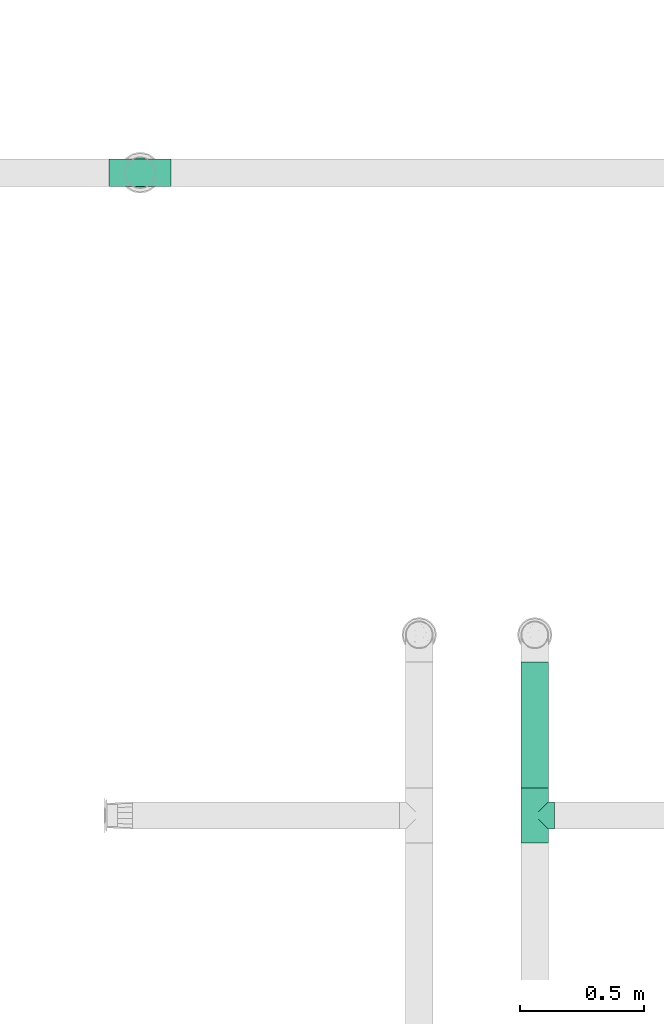
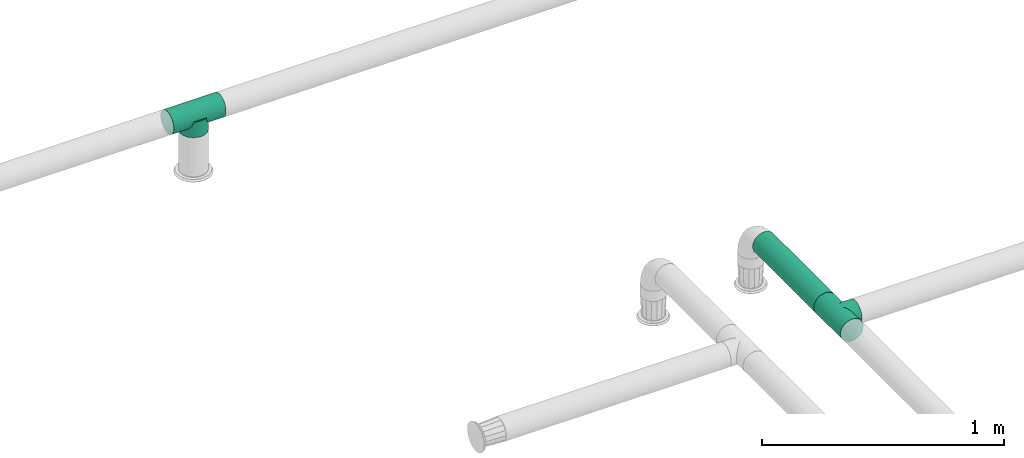
# One storey, part 75 of 115: 2 flow fittings, 1 flow segment.
"""IFC2X3 building model written with IfcOpenShell, lengths in millimetres."""

from ifc_helpers import new_model, entity, si_unit, converted_unit, derived_unit, direction, frame, origin_with_axes, origin_2d_with_axis, place, context, subcontext, project, spatial, hollow_circle, extrude, open_shell, surface_model, source, transform, mapped, material, layer, layer_set, layer_usage, type_object, element, save


model = new_model("IFC2X3")

# Units and contexts
model_context = context("Model", 3, precision=1e-05, world=origin_with_axes(), true_north=direction((0.0, 1.0)))
body_context = subcontext(model_context, "Body", "Model", "MODEL_VIEW")
ifc_project = project(units=[si_unit("AREAUNIT", "SQUARE_METRE"), si_unit("VOLUMEUNIT", "CUBIC_METRE", prefix="DECI"), si_unit("TIMEUNIT", "SECOND"), si_unit("THERMODYNAMICTEMPERATUREUNIT", "DEGREE_CELSIUS"), si_unit("PRESSUREUNIT", "PASCAL"), si_unit("MASSUNIT", "GRAM", prefix="KILO"), si_unit("LENGTHUNIT", "METRE", prefix="MILLI"), si_unit("POWERUNIT", "WATT"), si_unit("ELECTRICCURRENTUNIT", "AMPERE"), si_unit("ELECTRICVOLTAGEUNIT", "VOLT"), derived_unit("VOLUMETRICFLOWRATEUNIT", [(si_unit("VOLUMEUNIT", "CUBIC_METRE", prefix="DECI"), 1), (si_unit("TIMEUNIT", "SECOND"), -1)]), derived_unit("LINEARVELOCITYUNIT", [(si_unit("LENGTHUNIT", "METRE"), 1), (si_unit("TIMEUNIT", "SECOND"), -1)]), derived_unit("MASSDENSITYUNIT", [(si_unit("MASSUNIT", "GRAM", prefix="KILO"), 1), (si_unit("VOLUMEUNIT", "CUBIC_METRE"), -1)]), converted_unit("PLANEANGLEUNIT", "DEGREE", entity("IfcRatioMeasure", 0.01745), si_unit("PLANEANGLEUNIT", "RADIAN"), dimensions=[0, 0, 0, 0, 0, 0, 0])], contexts=[model_context])

# Site, building, storey
site_placement = place(None, origin_with_axes())
site = spatial("IfcSite", under=ifc_project, at=site_placement, CompositionType="ELEMENT")
building_placement = place(site_placement, origin_with_axes())
building = spatial("IfcBuilding", under=site, at=building_placement, Name="mc-building", CompositionType="ELEMENT")
storey_placement = place(building_placement, frame((0.0, 0.0, 2950.0), z_axis=(0.0, 0.0, 1.0), x_axis=(1.0, 0.0, 0.0)))
storey = spatial("IfcBuildingStorey", under=building, at=storey_placement, Name="2. Korrus", CompositionType="ELEMENT", Elevation=2950.0)

# Flow fittings
duct_fitting_type = type_object("IfcDuctFittingType", PredefinedType="JUNCTION")
shared_shape_1 = source(origin_with_axes(), body_context, "Body", "SurfaceModel", [
    surface_model("IfcShellBasedSurfaceModel", [(0.0, -80.0, -55.0), (14.23505, -80.0, -53.12592), (-14.23505, -80.0, -53.12592), (-53.12592, -80.0, 14.23505), (-27.5, -80.0, -47.63139), (-47.63139, -80.0, -27.5), (-38.89087, -80.0, -38.89087), (55.0, -80.0, 0.0), (53.12592, -80.0, 14.23505), (38.89087, -80.0, -38.89087), (27.5, -80.0, -47.63139), (53.12592, -80.0, -14.23505), (47.63139, -80.0, -27.5), (-53.12592, -80.0, -14.23505), (-47.63139, -80.0, 27.5), (-38.89087, -80.0, 38.89087), (14.23505, -80.0, 53.12592), (-27.5, -80.0, 47.63139), (-14.23505, -80.0, 53.12592), (47.63139, -80.0, 27.5), (38.89087, -80.0, 38.89087), (27.5, -80.0, 47.63139), (0.0, -80.0, 55.0), (-55.0, -80.0, 0.0), (0.0, 0.0, 55.0), (-7.4066, -7.4066, 54.49901), (-14.74521, -14.74521, 52.98659), (-21.93978, -21.93978, 50.43457), (-28.89905, -28.89905, 46.79578), (-35.50357, -35.50357, 42.00591), (-41.58668, -41.58668, 35.99373), (-46.92319, -46.92319, 28.69171), (-51.19777, -51.19777, 20.0945), (-50.37866, -80.0, 20.86752), (-54.01174, -54.01174, 10.37938), (-55.0, -55.0, 0.0), (-54.06296, -80.0, 7.11752), (-54.01174, -54.01174, -10.37938), (-51.19777, -51.19777, -20.0945), (-54.06296, -80.0, -7.11752), (-46.92319, -46.92319, -28.69171), (-41.58668, -41.58668, -35.99373), (-50.37866, -80.0, -20.86752), (-35.50357, -35.50357, -42.00591), (-21.93978, -21.93978, -50.43457), (-14.74521, -14.74521, -52.98659), (-7.4066, -7.4066, -54.49901), (0.0, 0.0, -55.0), (-28.89905, -28.89905, -46.79578), (7.4066, -7.4066, -54.49901), (14.74521, -14.74521, -52.98659), (21.93978, -21.93978, -50.43457), (28.89905, -28.89905, -46.79578), (35.50357, -35.50357, -42.00591), (41.58668, -41.58668, -35.99373), (46.92319, -46.92319, -28.69171), (51.19777, -51.19777, -20.0945), (50.37866, -80.0, -20.86752), (54.01174, -54.01174, -10.37938), (55.0, -55.0, 0.0), (54.06296, -80.0, -7.11752), (54.01174, -54.01174, 10.37938), (51.19777, -51.19777, 20.0945), (54.06296, -80.0, 7.11752), (46.92319, -46.92319, 28.69171), (41.58668, -41.58668, 35.99373), (50.37866, -80.0, 20.86752), (35.50357, -35.50357, 42.00591), (21.93978, -21.93978, 50.43457), (14.74521, -14.74521, 52.98659), (7.4066, -7.4066, 54.49901), (28.89905, -28.89905, 46.79578), (-110.0, 0.0, -55.0), (-110.0, -14.23505, -53.12592), (-110.0, 14.23505, -53.12592), (-110.0, 53.12592, 14.23505), (-110.0, 27.5, -47.63139), (-110.0, 47.63139, -27.5), (-110.0, 38.89087, -38.89087), (-110.0, -55.0, 0.0), (-110.0, -53.12592, 14.23505), (-110.0, -38.89087, -38.89087), (-110.0, -27.5, -47.63139), (-110.0, -53.12592, -14.23505), (-110.0, -47.63139, -27.5), (-110.0, 53.12592, -14.23505), (-110.0, 47.63139, 27.5), (-110.0, 38.89087, 38.89087), (-110.0, -14.23505, 53.12592), (-110.0, 27.5, 47.63139), (-110.0, 14.23505, 53.12592), (-110.0, -47.63139, 27.5), (-110.0, -38.89087, 38.89087), (-110.0, -27.5, 47.63139), (-110.0, 0.0, 55.0), (-110.0, 55.0, 0.0), (110.0, 55.0, 0.0), (110.0, 0.0, -55.0), (110.0, 14.23505, -53.12592), (110.0, 27.5, -47.63139), (110.0, 38.89087, -38.89087), (110.0, 47.63139, -27.5), (110.0, -38.89087, -38.89087), (110.0, -53.12592, 14.23505), (110.0, -27.5, -47.63139), (110.0, -14.23505, -53.12592), (110.0, -47.63139, -27.5), (110.0, -53.12592, -14.23505), (110.0, -55.0, 0.0), (110.0, 53.12592, -14.23505), (110.0, 53.12592, 14.23505), (110.0, 47.63139, 27.5), (110.0, 38.89087, 38.89087), (110.0, 0.0, 55.0), (110.0, 27.5, 47.63139), (110.0, 14.23505, 53.12592), (110.0, -47.63139, 27.5), (110.0, -38.89087, 38.89087), (110.0, -27.5, 47.63139), (110.0, -14.23505, 53.12592)], [open_shell([[[0, 1, 2]], [[2, 3, 4]], [[5, 6, 3]], [[6, 4, 3]], [[2, 7, 8]], [[9, 7, 10]], [[1, 10, 7]], [[11, 7, 12]], [[9, 12, 7]], [[7, 2, 1]], [[5, 3, 13]], [[2, 14, 3]], [[2, 15, 14]], [[2, 16, 17]], [[17, 15, 2]], [[16, 18, 17]], [[2, 8, 19]], [[2, 19, 20]], [[2, 20, 21]], [[16, 2, 21]], [[16, 22, 18]], [[23, 13, 3]], [[24, 25, 22]], [[26, 27, 18]], [[25, 26, 18]], [[22, 25, 18]], [[17, 28, 29]], [[17, 18, 27]], [[17, 29, 15]], [[28, 17, 27]], [[30, 31, 14]], [[32, 3, 33]], [[32, 34, 3]], [[35, 36, 34]], [[31, 32, 14]], [[15, 30, 14]], [[34, 36, 3]], [[33, 14, 32]], [[36, 35, 23]], [[30, 15, 29]], [[37, 38, 13]], [[37, 13, 39]], [[40, 41, 5]], [[38, 5, 42]], [[38, 40, 5]], [[37, 39, 35]], [[35, 39, 23]], [[13, 38, 42]], [[41, 6, 5]], [[41, 43, 6]], [[44, 45, 2]], [[46, 47, 0]], [[45, 46, 2]], [[43, 48, 4]], [[44, 4, 48]], [[44, 2, 4]], [[46, 0, 2]], [[43, 4, 6]], [[47, 49, 0]], [[50, 51, 1]], [[49, 50, 1]], [[0, 49, 1]], [[10, 52, 53]], [[10, 1, 51]], [[10, 53, 9]], [[52, 10, 51]], [[54, 55, 12]], [[56, 11, 57]], [[56, 58, 11]], [[59, 60, 58]], [[55, 56, 12]], [[9, 54, 12]], [[58, 60, 11]], [[57, 12, 56]], [[60, 59, 7]], [[54, 9, 53]], [[61, 62, 8]], [[61, 8, 63]], [[64, 65, 19]], [[62, 19, 66]], [[62, 64, 19]], [[61, 63, 59]], [[7, 59, 63]], [[62, 66, 8]], [[65, 20, 19]], [[65, 67, 20]], [[68, 69, 16]], [[70, 24, 22]], [[69, 70, 16]], [[67, 71, 21]], [[68, 21, 71]], [[68, 16, 21]], [[70, 22, 16]], [[67, 21, 20]], [[72, 73, 74]], [[74, 75, 76]], [[77, 78, 75]], [[76, 75, 78]], [[74, 79, 80]], [[81, 79, 82]], [[73, 82, 79]], [[83, 79, 84]], [[81, 84, 79]], [[79, 74, 73]], [[77, 75, 85]], [[74, 86, 75]], [[74, 87, 86]], [[74, 88, 89]], [[89, 87, 74]], [[88, 90, 89]], [[74, 91, 92]], [[91, 74, 80]], [[92, 93, 74]], [[74, 93, 88]], [[88, 94, 90]], [[95, 85, 75]], [[96, 97, 98]], [[99, 96, 98]], [[96, 100, 101]], [[100, 96, 99]], [[102, 97, 103]], [[97, 102, 104]], [[104, 105, 97]], [[102, 103, 106]], [[106, 103, 107]], [[108, 107, 103]], [[109, 96, 101]], [[110, 111, 97]], [[97, 111, 112]], [[113, 97, 114]], [[97, 112, 114]], [[113, 114, 115]], [[116, 103, 97]], [[117, 116, 97]], [[118, 117, 97]], [[119, 118, 97]], [[119, 97, 113]], [[96, 110, 97]], [[24, 113, 115]], [[89, 115, 114]], [[94, 24, 90]], [[90, 24, 115]], [[115, 89, 90]], [[114, 87, 89]], [[86, 112, 111]], [[75, 111, 110]], [[95, 110, 96]], [[87, 112, 86]], [[86, 111, 75]], [[110, 95, 75]], [[112, 87, 114]], [[85, 96, 109]], [[77, 109, 101]], [[95, 96, 85]], [[85, 109, 77]], [[101, 78, 77]], [[101, 100, 78]], [[76, 100, 99]], [[74, 99, 98]], [[47, 98, 97]], [[76, 99, 74]], [[47, 72, 74]], [[98, 47, 74]], [[100, 76, 78]], [[47, 46, 72]], [[45, 44, 73]], [[46, 45, 73]], [[72, 46, 73]], [[82, 48, 43]], [[82, 73, 44]], [[82, 43, 81]], [[48, 82, 44]], [[41, 40, 84]], [[38, 37, 83]], [[40, 38, 84]], [[81, 41, 84]], [[37, 79, 83]], [[83, 84, 38]], [[79, 37, 35]], [[41, 81, 43]], [[49, 97, 105]], [[105, 104, 51]], [[53, 104, 102]], [[53, 52, 104]], [[49, 47, 97]], [[51, 50, 105]], [[52, 51, 104]], [[49, 105, 50]], [[54, 102, 106]], [[56, 106, 107]], [[58, 107, 108]], [[55, 54, 106]], [[58, 56, 107]], [[59, 58, 108]], [[55, 106, 56]], [[102, 54, 53]], [[34, 32, 80]], [[31, 30, 91]], [[32, 31, 91]], [[35, 34, 79]], [[80, 79, 34]], [[32, 91, 80]], [[30, 92, 91]], [[30, 29, 92]], [[27, 26, 88]], [[25, 24, 94]], [[26, 25, 88]], [[29, 28, 93]], [[27, 93, 28]], [[27, 88, 93]], [[25, 94, 88]], [[29, 93, 92]], [[61, 108, 103]], [[62, 103, 116]], [[65, 116, 117]], [[61, 59, 108]], [[64, 62, 116]], [[65, 64, 116]], [[61, 103, 62]], [[117, 67, 65]], [[71, 67, 118]], [[118, 67, 117]], [[68, 118, 119]], [[70, 119, 113]], [[68, 71, 118]], [[70, 69, 119]], [[24, 70, 113]], [[68, 119, 69]]])]),
])
flow_fitting_1_placement = place(storey_placement, frame((30518.54047, 3666.26111, 2465.0), z_axis=(0.0, 0.0, 1.0), x_axis=(0.0, 1.0, 0.0)))
element("IfcFlowFitting", 1, at=flow_fitting_1_placement, inside=storey, type_object=duct_fitting_type, context=body_context, shape_type="MappedRepresentation", body=[
    mapped(shared_shape_1, transform((0.0, 0.0, 0.0), scale=1.0)),
])
shared_shape_2 = source(origin_with_axes(), body_context, "Body", "SurfaceModel", [
    surface_model("IfcShellBasedSurfaceModel", [(0.0, -80.0, -62.5), (16.17619, -80.0, -60.37037), (-16.17619, -80.0, -60.37037), (-60.37037, -80.0, 16.17619), (-31.25, -80.0, -54.12659), (-44.19417, -80.0, -44.19417), (-54.12659, -80.0, -31.25), (62.5, -80.0, 0.0), (60.37037, -80.0, 16.17619), (44.19417, -80.0, -44.19417), (31.25, -80.0, -54.12659), (60.37037, -80.0, -16.17619), (54.12659, -80.0, -31.25), (-60.37037, -80.0, -16.17619), (-54.12659, -80.0, 31.25), (-44.19417, -80.0, 44.19417), (-31.25, -80.0, 54.12659), (-16.17619, -80.0, 60.37037), (16.17619, -80.0, 60.37037), (54.12659, -80.0, 31.25), (44.19417, -80.0, 44.19417), (31.25, -80.0, 54.12659), (0.0, -80.0, 62.5), (-62.5, -80.0, 0.0), (0.0, 0.0, 62.5), (-15.31424, 0.0, 60.59475), (-29.68586, 0.0, 55.0), (-31.79332, -11.38268, 53.80924), (-62.5, -55.0, 0.0), (-61.43518, -80.0, 8.0881), (-61.42389, -53.77401, 11.548), (-36.65815, -21.50744, 50.62045), (-42.49909, -30.41254, 45.8266), (-48.42243, -38.25549, 39.51605), (-53.88367, -44.96887, 31.66703), (-58.39386, -50.28512, 22.28019), (-61.42389, -53.77401, -11.548), (-58.39386, -50.28512, -22.28019), (-53.88367, -44.96887, -31.66703), (-48.42243, -38.25549, -39.51605), (-61.43518, -80.0, -8.0881), (-42.49909, -30.41254, -45.8266), (-31.79332, -11.38268, -53.80924), (-29.68586, 0.0, -55.0), (-15.31424, 0.0, -60.59475), (0.0, 0.0, -62.5), (-36.65815, -21.50744, -50.62045), (15.31424, 0.0, -60.59475), (29.68586, 0.0, -55.0), (31.79332, -11.38268, -53.80924), (62.5, -55.0, 0.0), (61.43518, -80.0, -8.0881), (61.42389, -53.77401, -11.548), (36.65815, -21.50744, -50.62045), (42.49909, -30.41254, -45.8266), (48.42243, -38.25549, -39.51605), (53.88367, -44.96887, -31.66703), (58.39386, -50.28512, -22.28019), (61.42389, -53.77401, 11.548), (58.39386, -50.28512, 22.28019), (53.88367, -44.96887, 31.66703), (48.42243, -38.25549, 39.51605), (61.43518, -80.0, 8.0881), (42.49909, -30.41254, 45.8266), (31.79332, -11.38268, 53.80924), (29.68586, 0.0, 55.0), (15.31424, 0.0, 60.59475), (36.65815, -21.50744, 50.62045), (-125.0, 0.0, -55.0), (-125.0, -14.23505, -53.12592), (-125.0, 14.23505, -53.12592), (-125.0, 53.12592, 14.23505), (-125.0, 27.5, -47.63139), (-125.0, 47.63139, -27.5), (-125.0, 38.89087, -38.89087), (-125.0, -55.0, 0.0), (-125.0, -53.12592, 14.23505), (-125.0, -38.89087, -38.89087), (-125.0, -27.5, -47.63139), (-125.0, -53.12592, -14.23505), (-125.0, -47.63139, -27.5), (-125.0, 53.12592, -14.23505), (-125.0, 47.63139, 27.5), (-125.0, 38.89087, 38.89087), (-125.0, -14.23505, 53.12592), (-125.0, 27.5, 47.63139), (-125.0, 14.23505, 53.12592), (-125.0, -47.63139, 27.5), (-125.0, -38.89087, 38.89087), (-125.0, -27.5, 47.63139), (-125.0, 0.0, 55.0), (-125.0, 55.0, 0.0), (125.0, 55.0, 0.0), (125.0, 0.0, -55.0), (125.0, 14.23505, -53.12592), (125.0, 27.5, -47.63139), (125.0, 38.89087, -38.89087), (125.0, 47.63139, -27.5), (125.0, -38.89087, -38.89087), (125.0, -53.12592, 14.23505), (125.0, -27.5, -47.63139), (125.0, -14.23505, -53.12592), (125.0, -47.63139, -27.5), (125.0, -53.12592, -14.23505), (125.0, -55.0, 0.0), (125.0, 53.12592, -14.23505), (125.0, 53.12592, 14.23505), (125.0, 47.63139, 27.5), (125.0, 38.89087, 38.89087), (125.0, 0.0, 55.0), (125.0, 27.5, 47.63139), (125.0, 14.23505, 53.12592), (125.0, -47.63139, 27.5), (125.0, -38.89087, 38.89087), (125.0, -27.5, 47.63139), (125.0, -14.23505, 53.12592)], [open_shell([[[0, 1, 2]], [[2, 3, 4]], [[5, 3, 6]], [[4, 3, 5]], [[2, 7, 8]], [[9, 7, 10]], [[1, 10, 7]], [[11, 7, 12]], [[9, 12, 7]], [[7, 2, 1]], [[13, 6, 3]], [[2, 14, 3]], [[2, 15, 14]], [[16, 2, 17]], [[16, 15, 2]], [[17, 2, 18]], [[19, 20, 2]], [[19, 2, 8]], [[20, 21, 2]], [[2, 21, 18]], [[18, 22, 17]], [[23, 13, 3]], [[22, 24, 25]], [[26, 27, 25]], [[28, 29, 30]], [[17, 25, 27]], [[22, 25, 17]], [[16, 31, 32]], [[16, 17, 27]], [[16, 32, 15]], [[31, 16, 27]], [[33, 34, 14]], [[35, 30, 3]], [[34, 35, 14]], [[15, 33, 14]], [[30, 29, 3]], [[3, 14, 35]], [[29, 28, 23]], [[33, 15, 32]], [[36, 37, 13]], [[38, 39, 6]], [[37, 38, 6]], [[36, 40, 28]], [[28, 40, 23]], [[13, 37, 6]], [[39, 5, 6]], [[39, 41, 5]], [[42, 43, 44]], [[36, 13, 40]], [[42, 44, 2]], [[0, 44, 45]], [[41, 46, 4]], [[42, 4, 46]], [[42, 2, 4]], [[44, 0, 2]], [[41, 4, 5]], [[0, 45, 47]], [[48, 49, 47]], [[50, 51, 52]], [[1, 47, 49]], [[0, 47, 1]], [[10, 53, 54]], [[10, 1, 49]], [[10, 54, 9]], [[53, 10, 49]], [[55, 56, 12]], [[57, 52, 11]], [[56, 57, 12]], [[9, 55, 12]], [[52, 51, 11]], [[11, 12, 57]], [[51, 50, 7]], [[55, 9, 54]], [[58, 59, 8]], [[60, 61, 19]], [[59, 60, 19]], [[58, 62, 50]], [[7, 50, 62]], [[59, 19, 8]], [[61, 20, 19]], [[61, 63, 20]], [[64, 65, 66]], [[58, 8, 62]], [[64, 66, 18]], [[22, 66, 24]], [[63, 67, 21]], [[64, 21, 67]], [[64, 18, 21]], [[66, 22, 18]], [[63, 21, 20]], [[68, 69, 70]], [[70, 71, 72]], [[73, 74, 71]], [[72, 71, 74]], [[70, 75, 76]], [[77, 75, 78]], [[69, 78, 75]], [[79, 75, 80]], [[77, 80, 75]], [[75, 70, 69]], [[73, 71, 81]], [[70, 82, 71]], [[70, 83, 82]], [[70, 84, 85]], [[85, 83, 70]], [[84, 86, 85]], [[70, 87, 88]], [[87, 70, 76]], [[88, 89, 70]], [[70, 89, 84]], [[84, 90, 86]], [[91, 81, 71]], [[92, 93, 94]], [[95, 92, 94]], [[92, 96, 97]], [[96, 92, 95]], [[98, 93, 99]], [[93, 98, 100]], [[100, 101, 93]], [[98, 99, 102]], [[102, 99, 103]], [[104, 103, 99]], [[105, 92, 97]], [[106, 107, 93]], [[93, 107, 108]], [[109, 93, 110]], [[93, 108, 110]], [[109, 110, 111]], [[112, 99, 93]], [[113, 112, 93]], [[114, 113, 93]], [[115, 114, 93]], [[115, 93, 109]], [[92, 106, 93]], [[65, 109, 111]], [[65, 111, 86]], [[85, 111, 110]], [[90, 26, 86]], [[86, 26, 65]], [[111, 85, 86]], [[110, 83, 85]], [[82, 108, 107]], [[71, 107, 106]], [[91, 106, 92]], [[83, 108, 82]], [[82, 107, 71]], [[106, 91, 71]], [[108, 83, 110]], [[81, 92, 105]], [[73, 105, 97]], [[74, 97, 96]], [[91, 92, 81]], [[81, 105, 73]], [[97, 74, 73]], [[96, 72, 74]], [[70, 95, 94]], [[93, 48, 94]], [[43, 94, 48]], [[72, 95, 70]], [[43, 68, 70]], [[94, 43, 70]], [[95, 72, 96]], [[68, 43, 42]], [[69, 42, 46]], [[78, 46, 41]], [[68, 42, 69]], [[77, 41, 39]], [[78, 69, 46]], [[41, 77, 78]], [[38, 37, 80]], [[36, 28, 75]], [[37, 36, 79]], [[77, 38, 80]], [[80, 37, 79]], [[36, 75, 79]], [[38, 77, 39]], [[49, 93, 101]], [[101, 100, 53]], [[98, 54, 100]], [[98, 55, 54]], [[48, 93, 49]], [[49, 101, 53]], [[100, 54, 53]], [[56, 98, 102]], [[57, 102, 103]], [[52, 103, 104]], [[57, 56, 102]], [[50, 52, 104]], [[57, 103, 52]], [[98, 56, 55]], [[28, 30, 75]], [[35, 34, 87]], [[30, 35, 76]], [[75, 30, 76]], [[76, 35, 87]], [[34, 88, 87]], [[34, 33, 88]], [[89, 32, 31]], [[31, 27, 84]], [[26, 90, 27]], [[32, 88, 33]], [[32, 89, 88]], [[89, 31, 84]], [[27, 90, 84]], [[58, 104, 99]], [[59, 99, 112]], [[60, 112, 113]], [[58, 50, 104]], [[60, 59, 112]], [[58, 99, 59]], [[113, 61, 60]], [[61, 113, 63]], [[63, 113, 114]], [[67, 114, 115]], [[64, 115, 109]], [[63, 114, 67]], [[64, 67, 115]], [[65, 64, 109]], [[65, 26, 24]], [[65, 24, 66]], [[24, 26, 25]], [[47, 45, 48]], [[43, 48, 45]], [[43, 45, 44]]])]),
])
flow_fitting_2_placement = place(storey_placement, frame((28929.65714, 6254.72535, 2480.0), z_axis=(0.0, -1.0, 0.0), x_axis=(1.0, 0.0, 0.0)))
element("IfcFlowFitting", 2, at=flow_fitting_2_placement, inside=storey, type_object=duct_fitting_type, context=body_context, shape_type="MappedRepresentation", body=[
    mapped(shared_shape_2, transform((0.0, 0.0, 0.0), scale=1.0)),
])

# Flow segment
ifc_material = material(Name="FZ1")
ifc_layer = layer(ifc_material, 0.0)
ifc_layer_set = layer_set([ifc_layer], Name="FZ1")
ifc_layer_usage = layer_usage(ifc_layer_set, "AXIS1", "POSITIVE", 0.0)
duct_segment_type = type_object("IfcDuctSegmentType", PredefinedType="RIGIDSEGMENT")
shared_shape_3 = source(origin_with_axes(), body_context, "Body", "SweptSolid", [
    extrude(hollow_circle(Radius=55.0, WallThickness=2.0, at=origin_2d_with_axis()), frame((0.0, 0.0, 0.0), z_axis=(1.0, 0.0, 0.0), x_axis=(0.0, 1.0, 0.0)), (0.0, 0.0, 1.0), 507.6),
])
flow_segment_placement = place(storey_placement, frame((30518.54047, 3776.26111, 2465.0), z_axis=(0.0, 0.0, 1.0), x_axis=(0.0, 1.0, 0.0)))
element("IfcFlowSegment", 3, at=flow_segment_placement, inside=storey, type_object=duct_segment_type, material=ifc_layer_usage, context=body_context, shape_type="MappedRepresentation", body=[
    mapped(shared_shape_3, transform((0.0, 0.0, 0.0), scale=1.0)),
])

save(model, "model.ifc")
